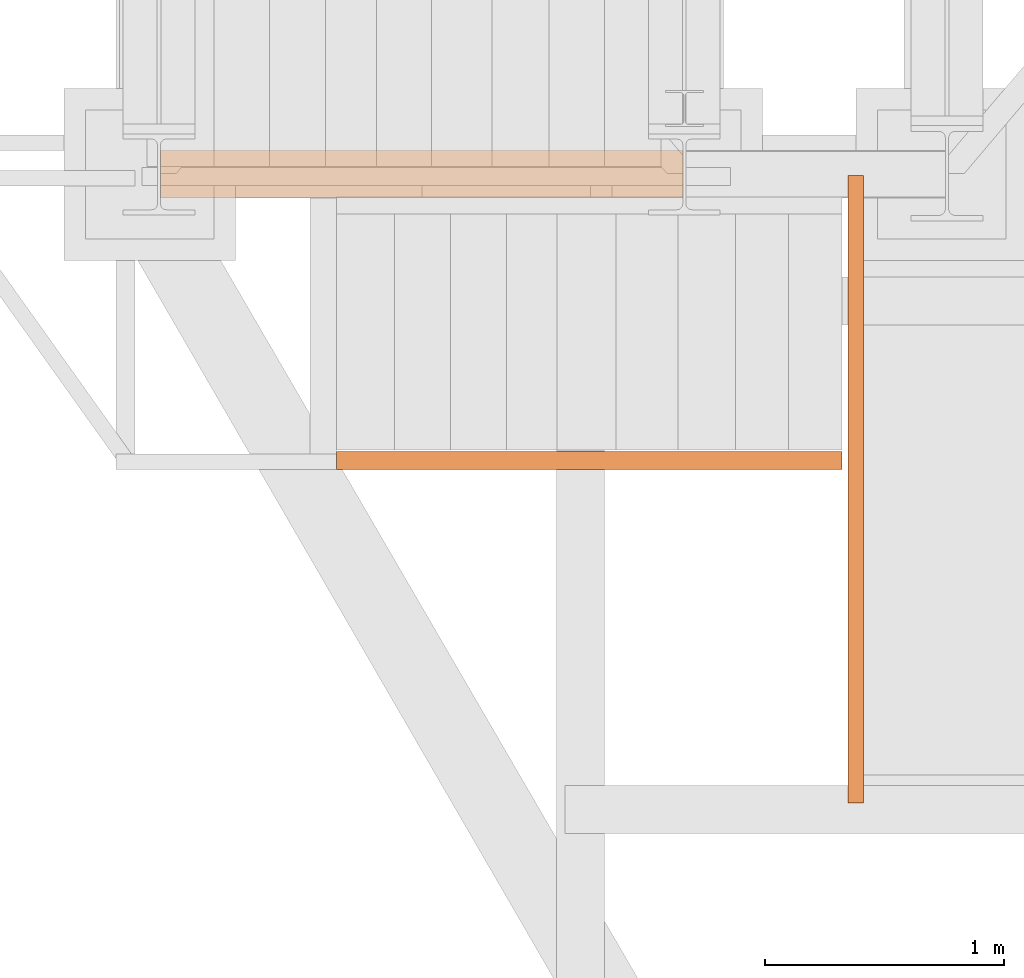
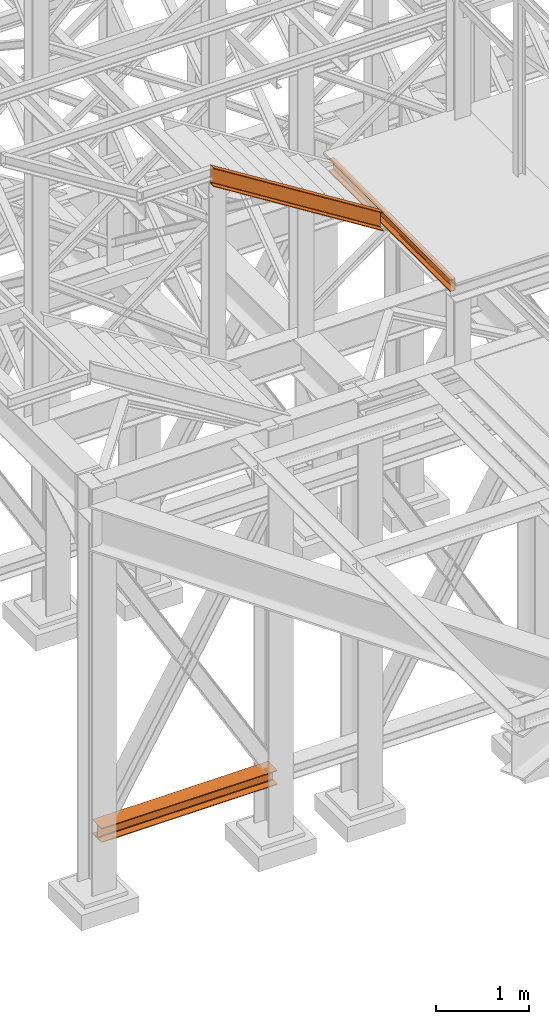
# One storey, part 19 of 208: 3 proxies.
"""IFC2X3 building model written with IfcOpenShell, lengths in millimetres."""

from ifc_helpers import new_model, entity, si_unit, converted_unit, frame, origin, origin_with_axes, place, context, subcontext, project, spatial, faceted_brep, element, save


model = new_model("IFC2X3")

# Units and contexts
model_context = context("Model", 3, precision=1e-05, world=origin())
plan_context = context("Plan", 3, precision=1e-05, world=origin())
body_context = subcontext(model_context, "Body", "Model", "MODEL_VIEW")
ifc_project = project(units=[si_unit("LENGTHUNIT", "METRE", prefix="MILLI"), converted_unit("PLANEANGLEUNIT", "DEGREE", entity("IfcPlaneAngleMeasure", 0.0174532925199433), si_unit("PLANEANGLEUNIT", "RADIAN"), dimensions=[0, 0, 0, 0, 0, 0, 0]), si_unit("AREAUNIT", "SQUARE_METRE"), si_unit("VOLUMEUNIT", "CUBIC_METRE")], contexts=[model_context, plan_context])

# Building, storey
building_placement = place(None, origin())
building = spatial("IfcBuilding", under=ifc_project, at=building_placement, CompositionType="COMPLEX")
storey_placement = place(building_placement, origin_with_axes())
storey = spatial("IfcBuildingStorey", under=building, at=storey_placement, Name="Geschoss", CompositionType="ELEMENT")

# Proxies
proxy_1_placement = place(storey_placement, frame((-3299.995025406559, -17362.5323246858, 544.9900024165573), z_axis=(0.0, 0.0, 1.0), x_axis=(1.0, 0.0, 0.0)))
element("IfcBuildingElementProxy", 1, at=proxy_1_placement, inside=storey, context=body_context, shape_type="Brep", body=[
    faceted_brep([(2188.00999989569, 0.00999999999839929, 190.0100125169756), (2188.00999989569, 200.0100029802306, 190.0100125169756), (2188.00999989569, 200.0100029802306, 180.0100146031382), (2188.00999989569, 121.2600035762771, 180.0100071525576), (2188.00999989569, 111.9441915473326, 178.1454621052744), (2188.00999989569, 105.1245498640819, 171.3258190250399), (2188.00999989569, 103.2600015571697, 162.010007927418), (2188.00999989569, 103.2600015571697, 28.00999713897727), (2188.00999989569, 105.1245498640819, 18.69418604135535), (2188.00999989569, 111.9441915473326, 11.87454296112082), (2188.00999989569, 121.2600035762771, 10.00999791383765), (2188.00999989569, 200.0100029802306, 10.00999791383765), (2188.00999989569, 200.0100029802306, 0.01000000000021828), (2188.00999989569, 0.00999999999839929, 0.01000000000021828), (2188.00999989569, 0.00999999999839929, 10.00999791383765), (2188.00999989569, 78.75999940395195, 10.00999791383765), (2188.00999989569, 88.07581143289644, 11.87454296112082), (2188.00999989569, 94.89545311614711, 18.69418604135535), (2188.00999989569, 96.7600014230593, 28.00999713897727), (2188.00999989569, 96.7600014230593, 162.010007927418), (2188.00999989569, 94.89545311614711, 171.3258190250399), (2188.00999989569, 88.07581143289644, 178.1454621052744), (2188.00999989569, 78.75999940395195, 180.0100071525576), (2188.00999989569, 0.00999999999839929, 180.0100146031382), (2188.00999989569, 200.0100029802306, 190.0100125169756), (2188.00999989569, 0.00999999999839929, 190.0100125169756), (0.01000000000021828, 0.00999999999839929, 190.0100125169755), (0.01000000000021828, 200.0100029802306, 190.0100125169755), (2188.00999989569, 200.0100029802306, 180.0100146031382), (2188.00999989569, 200.0100029802306, 190.0100125169756), (0.01000000000021828, 200.0100029802306, 190.0100125169755), (0.01000000000021828, 200.0100029802306, 180.0100146031381), (2188.00999989569, 121.2600035762771, 180.0100071525576), (2188.00999989569, 200.0100029802306, 180.0100146031382), (0.01000000000021828, 200.0100029802306, 180.0100146031381), (0.01000000000021828, 121.2600035762771, 180.0100071525575), (2188.00999989569, 111.9441915473326, 178.1454621052744), (2188.00999989569, 121.2600035762771, 180.0100071525576), (0.01000000000021828, 121.2600035762771, 180.0100071525575), (0.01000000000021828, 111.9441915473326, 178.1454621052743), (2188.00999989569, 105.1245498640819, 171.3258190250399), (2188.00999989569, 111.9441915473326, 178.1454621052744), (0.01000000000021828, 111.9441915473326, 178.1454621052743), (0.01000000000021828, 105.1245498640819, 171.3258190250398), (2188.00999989569, 103.2600015571697, 162.010007927418), (2188.00999989569, 105.1245498640819, 171.3258190250399), (0.01000000000021828, 105.1245498640819, 171.3258190250398), (0.01000000000021828, 103.2600015571697, 162.0100079274179), (2188.00999989569, 103.2600015571697, 28.00999713897727), (2188.00999989569, 103.2600015571697, 162.010007927418), (0.01000000000021828, 103.2600015571697, 162.0100079274179), (0.01000000000021828, 103.2600015571697, 28.00999713897716), (2188.00999989569, 105.1245498640819, 18.69418604135535), (2188.00999989569, 103.2600015571697, 28.00999713897727), (0.01000000000021828, 103.2600015571697, 28.00999713897716), (0.01000000000021828, 105.1245498640819, 18.69418604135524), (2188.00999989569, 111.9441915473326, 11.87454296112082), (2188.00999989569, 105.1245498640819, 18.69418604135535), (0.01000000000021828, 105.1245498640819, 18.69418604135524), (0.01000000000021828, 111.9441915473326, 11.87454296112071), (2188.00999989569, 121.2600035762771, 10.00999791383765), (2188.00999989569, 111.9441915473326, 11.87454296112082), (0.01000000000021828, 111.9441915473326, 11.87454296112071), (0.01000000000021828, 121.2600035762771, 10.00999791383754), (2188.00999989569, 200.0100029802306, 10.00999791383765), (2188.00999989569, 121.2600035762771, 10.00999791383765), (0.01000000000021828, 121.2600035762771, 10.00999791383754), (0.01000000000021828, 200.0100029802306, 10.00999791383754), (2188.00999989569, 200.0100029802306, 0.01000000000021828), (2188.00999989569, 200.0100029802306, 10.00999791383765), (0.01000000000021828, 200.0100029802306, 10.00999791383754), (0.01000000000021828, 200.0100029802306, 0.01000000000010459), (2188.00999989569, 0.00999999999839929, 0.01000000000021828), (2188.00999989569, 200.0100029802306, 0.01000000000021828), (0.01000000000021828, 200.0100029802306, 0.01000000000010459), (0.01000000000021828, 0.00999999999839929, 0.01000000000010459), (2188.00999989569, 0.00999999999839929, 10.00999791383765), (2188.00999989569, 0.00999999999839929, 0.01000000000021828), (0.01000000000021828, 0.00999999999839929, 0.01000000000010459), (0.01000000000021828, 0.00999999999839929, 10.00999791383754), (2188.00999989569, 78.75999940395195, 10.00999791383765), (2188.00999989569, 0.00999999999839929, 10.00999791383765), (0.01000000000021828, 0.00999999999839929, 10.00999791383754), (0.01000000000021828, 78.75999940395195, 10.00999791383754), (2188.00999989569, 88.07581143289644, 11.87454296112082), (2188.00999989569, 78.75999940395195, 10.00999791383765), (0.01000000000021828, 78.75999940395195, 10.00999791383754), (0.01000000000021828, 88.07581143289644, 11.87454296112071), (2188.00999989569, 94.89545311614711, 18.69418604135535), (2188.00999989569, 88.07581143289644, 11.87454296112082), (0.01000000000021828, 88.07581143289644, 11.87454296112071), (0.01000000000021828, 94.89545311614711, 18.69418604135524), (2188.00999989569, 96.7600014230593, 28.00999713897727), (2188.00999989569, 94.89545311614711, 18.69418604135535), (0.01000000000021828, 94.89545311614711, 18.69418604135524), (0.01000000000021828, 96.7600014230593, 28.00999713897716), (2188.00999989569, 96.7600014230593, 162.010007927418), (2188.00999989569, 96.7600014230593, 28.00999713897727), (0.01000000000021828, 96.7600014230593, 28.00999713897716), (0.01000000000021828, 96.7600014230593, 162.0100079274179), (2188.00999989569, 94.89545311614711, 171.3258190250399), (2188.00999989569, 96.7600014230593, 162.010007927418), (0.01000000000021828, 96.7600014230593, 162.0100079274179), (0.01000000000021828, 94.89545311614711, 171.3258190250398), (2188.00999989569, 88.07581143289644, 178.1454621052744), (2188.00999989569, 94.89545311614711, 171.3258190250399), (0.01000000000021828, 94.89545311614711, 171.3258190250398), (0.01000000000021828, 88.07581143289644, 178.1454621052743), (2188.00999989569, 78.75999940395195, 180.0100071525576), (2188.00999989569, 88.07581143289644, 178.1454621052744), (0.01000000000021828, 88.07581143289644, 178.1454621052743), (0.01000000000021828, 78.75999940395195, 180.0100071525575), (2188.00999989569, 0.00999999999839929, 180.0100146031382), (2188.00999989569, 78.75999940395195, 180.0100071525576), (0.01000000000021828, 78.75999940395195, 180.0100071525575), (0.01000000000021828, 0.00999999999839929, 180.0100146031381), (2188.00999989569, 0.00999999999839929, 190.0100125169756), (2188.00999989569, 0.00999999999839929, 180.0100146031382), (0.01000000000021828, 0.00999999999839929, 180.0100146031381), (0.01000000000021828, 0.00999999999839929, 190.0100125169755), (0.01000000000021828, 0.00999999999839929, 190.0100125169755), (0.01000000000021828, 0.00999999999839929, 180.0100146031381), (0.01000000000021828, 78.75999940395195, 180.0100071525575), (0.01000000000021828, 88.07581143289644, 178.1454621052743), (0.01000000000021828, 94.89545311614711, 171.3258190250398), (0.01000000000021828, 96.7600014230593, 162.0100079274179), (0.01000000000021828, 96.7600014230593, 28.00999713897716), (0.01000000000021828, 94.89545311614711, 18.69418604135524), (0.01000000000021828, 88.07581143289644, 11.87454296112071), (0.01000000000021828, 78.75999940395195, 10.00999791383754), (0.01000000000021828, 0.00999999999839929, 10.00999791383754), (0.01000000000021828, 0.00999999999839929, 0.01000000000010459), (0.01000000000021828, 200.0100029802306, 0.01000000000010459), (0.01000000000021828, 200.0100029802306, 10.00999791383754), (0.01000000000021828, 121.2600035762771, 10.00999791383754), (0.01000000000021828, 111.9441915473326, 11.87454296112071), (0.01000000000021828, 105.1245498640819, 18.69418604135524), (0.01000000000021828, 103.2600015571697, 28.00999713897716), (0.01000000000021828, 103.2600015571697, 162.0100079274179), (0.01000000000021828, 105.1245498640819, 171.3258190250398), (0.01000000000021828, 111.9441915473326, 178.1454621052743), (0.01000000000021828, 121.2600035762771, 180.0100071525575), (0.01000000000021828, 200.0100029802306, 180.0100146031381), (0.01000000000021828, 200.0100029802306, 190.0100125169755)], [[[0, 1, 2, 3, 4, 5, 6, 7, 8, 9, 10, 11, 12, 13, 14, 15, 16, 17, 18, 19, 20, 21, 22, 23]], [[24, 25, 26, 27]], [[28, 29, 30, 31]], [[32, 33, 34, 35]], [[36, 37, 38, 39]], [[40, 41, 42, 43]], [[44, 45, 46, 47]], [[48, 49, 50, 51]], [[52, 53, 54, 55]], [[56, 57, 58, 59]], [[60, 61, 62, 63]], [[64, 65, 66, 67]], [[68, 69, 70, 71]], [[72, 73, 74, 75]], [[76, 77, 78, 79]], [[80, 81, 82, 83]], [[84, 85, 86, 87]], [[88, 89, 90, 91]], [[92, 93, 94, 95]], [[96, 97, 98, 99]], [[100, 101, 102, 103]], [[104, 105, 106, 107]], [[108, 109, 110, 111]], [[112, 113, 114, 115]], [[116, 117, 118, 119]], [[120, 121, 122, 123, 124, 125, 126, 127, 128, 129, 130, 131, 132, 133, 134, 135, 136, 137, 138, 139, 140, 141, 142, 143]]], orient=[[False], [False], [False], [False], [False], [False], [False], [False], [False], [False], [False], [False], [False], [False], [False], [False], [False], [False], [False], [False], [False], [False], [False], [False], [False], [False]]),
])
proxy_2_placement = place(storey_placement, frame((-421.7450362397046, -19894.59359431297, 8324.990002086155), z_axis=(0.0, 0.0, 1.0), x_axis=(1.0, 0.0, 0.0)))
element("IfcBuildingElementProxy", 2, at=proxy_2_placement, inside=storey, context=body_context, shape_type="Brep", body=[
    faceted_brep([(65.00999999999999, 2627.529208944845, 160.0100000000002), (65.00999999999999, 0.00999999999839929, 160.0100000000002), (0.009999999999990905, 0.00999999999839929, 160.0100000000002), (0.009999999999990905, 2627.529208944845, 160.0100000000002), (0.009999999999990905, 2627.529208944845, 160.0100000000002), (0.009999999999990905, 0.00999999999839929, 160.0100000000002), (0.009999999999990905, 0.00999999999839929, 156.8875719297539), (0.009999999999990905, 2627.529208944845, 156.8875719297539), (0.009999999999990905, 2627.529208944845, 156.8875719297539), (0.009999999999990905, 0.00999999999839929, 156.8875719297539), (0.2527365771727546, 0.00999999999839929, 155.2717110918293), (0.2527365771727546, 2627.529208944845, 155.2717110918293), (0.2527365771727546, 2627.529208944845, 155.2717110918293), (0.2527365771727546, 0.00999999999839929, 155.2717110918293), (0.9594677141446937, 0.00999999999839929, 153.7984655565542), (0.9594677141446937, 2627.529208944845, 153.7984655565542), (0.9594677141446937, 2627.529208944845, 153.7984655565542), (0.9594677141446937, 0.00999999999839929, 153.7984655565542), (2.067848361531787, 0.00999999999839929, 152.5978732961266), (2.067848361531787, 2627.529208944845, 152.5978732961266), (2.067848361531787, 2627.529208944845, 152.5978732961266), (2.067848361531787, 0.00999999999839929, 152.5978732961266), (3.480043588516992, 0.00999999999839929, 151.7759086082897), (3.480043588516992, 2627.529208944845, 151.7759086082897), (3.480043588516992, 2627.529208944845, 151.7759086082897), (3.480043588516992, 0.00999999999839929, 151.7759086082897), (5.07140127744583, 0.00999999999839929, 151.4050878978051), (5.07140127744583, 2627.529208944845, 151.4050878978051), (5.07140127744583, 2627.529208944845, 151.4050878978051), (5.07140127744583, 0.00999999999839929, 151.4050878978051), (47.84732483397033, 0.00999999999839929, 147.9830140132835), (47.84732483397033, 2627.529208944845, 147.9830140132835), (47.84732483397033, 2627.529208944845, 147.9830140132835), (47.84732483397033, 0.00999999999839929, 147.9830140132835), (50.81159179199108, 0.00999999999839929, 147.318026761528), (50.81159179199108, 2627.529208944845, 147.318026761528), (50.81159179199108, 2627.529208944845, 147.318026761528), (50.81159179199108, 0.00999999999839929, 147.318026761528), (53.58138040071367, 0.00999999999839929, 145.7058782528511), (53.58138040071367, 2627.529208944845, 145.7058782528511), (53.58138040071367, 2627.529208944845, 145.7058782528511), (53.58138040071367, 0.00999999999839929, 145.7058782528511), (55.69737981845333, 0.00999999999839929, 143.4138384829421), (55.69737981845333, 2627.529208944845, 143.4138384829421), (55.69737981845333, 2627.529208944845, 143.4138384829421), (55.69737981845333, 0.00999999999839929, 143.4138384829421), (57.04659380721364, 0.00999999999839929, 140.6012788246917), (57.04659380721364, 2627.529208944845, 140.6012788246917), (57.04659380721364, 2627.529208944845, 140.6012788246917), (57.04659380721364, 0.00999999999839929, 140.6012788246917), (57.50999999999999, 0.00999999999839929, 137.5164535886543), (57.50999999999999, 2627.529208944845, 137.5164535886543), (57.50999999999999, 2627.529208944845, 137.5164535886543), (57.50999999999999, 0.00999999999839929, 137.5164535886543), (57.50999999999999, 0.00999999999839929, 22.503546411348), (57.50999999999999, 2627.529208944845, 22.503546411348), (57.50999999999999, 2627.529208944845, 22.503546411348), (57.50999999999999, 0.00999999999839929, 22.503546411348), (57.04659380721364, 0.00999999999839929, 19.41872117530875), (57.04659380721364, 2627.529208944845, 19.41872117530875), (57.04659380721364, 2627.529208944845, 19.41872117530875), (57.04659380721364, 0.00999999999839929, 19.41872117530875), (55.69737981845333, 0.00999999999839929, 16.60616151705835), (55.69737981845333, 2627.529208944845, 16.60616151705835), (55.69737981845333, 2627.529208944845, 16.60616151705835), (55.69737981845333, 0.00999999999839929, 16.60616151705835), (53.58138040071367, 0.00999999999839929, 14.31412174714933), (53.58138040071367, 2627.529208944845, 14.31412174714933), (53.58138040071367, 2627.529208944845, 14.31412174714933), (53.58138040071367, 0.00999999999839929, 14.31412174714933), (50.88537133101795, 0.00999999999839929, 12.74491643400688), (50.88537133101795, 2627.529208944845, 12.74491643400688), (50.88537133101795, 2627.529208944845, 12.74491643400688), (50.88537133101795, 0.00999999999839929, 12.74491643400688), (47.84732483397033, 0.00999999999839929, 12.03698598671872), (47.84732483397033, 2627.529208944845, 12.03698598671872), (47.84732483397033, 2627.529208944845, 12.03698598671872), (47.84732483397033, 0.00999999999839929, 12.03698598671872), (5.07140127744583, 0.00999999999839929, 8.614912102195376), (5.07140127744583, 2627.529208944845, 8.614912102195376), (5.07140127744583, 2627.529208944845, 8.614912102195376), (5.07140127744583, 0.00999999999839929, 8.614912102195376), (3.480043588516992, 0.00999999999839929, 8.244091391710754), (3.480043588516992, 2627.529208944845, 8.244091391710754), (3.480043588516992, 2627.529208944845, 8.244091391710754), (3.480043588516992, 0.00999999999839929, 8.244091391710754), (2.067848361531787, 0.00999999999839929, 7.422126703873801), (2.067848361531787, 2627.529208944845, 7.422126703873801), (2.067848361531787, 2627.529208944845, 7.422126703873801), (2.067848361531787, 0.00999999999839929, 7.422126703873801), (0.9594677141446937, 0.00999999999839929, 6.221534443446217), (0.9594677141446937, 2627.529208944845, 6.221534443446217), (0.9594677141446937, 2627.529208944845, 6.221534443446217), (0.9594677141446937, 0.00999999999839929, 6.221534443446217), (0.2527365771727546, 0.00999999999839929, 4.748288908172981), (0.2527365771727546, 2627.529208944845, 4.748288908172981), (0.2527365771727546, 2627.529208944845, 4.748288908172981), (0.2527365771727546, 0.00999999999839929, 4.748288908172981), (0.009999999999990905, 0.00999999999839929, 0.01000000000021828), (0.009999999999990905, 2627.529208944845, 0.01000000000021828), (0.009999999999990905, 2627.529208944845, 0.01000000000021828), (0.009999999999990905, 0.00999999999839929, 0.01000000000021828), (65.00999999999999, 0.00999999999839929, 0.01000000000021828), (65.00999999999999, 2627.529208944845, 0.01000000000021828), (65.00999999999999, 2627.529208944845, 0.01000000000021828), (65.00999999999999, 0.00999999999839929, 0.01000000000021828), (65.00999999999999, 0.00999999999839929, 160.0100000000002), (65.00999999999999, 2627.529208944845, 160.0100000000002), (65.00999999999999, 2627.529208944845, 160.0100000000002), (0.009999999999990905, 2627.529208944845, 160.0100000000002), (0.009999999999990905, 2627.529208944845, 156.8875719297539), (0.2527365771727546, 2627.529208944845, 155.2717110918293), (0.9594677141446937, 2627.529208944845, 153.7984655565542), (2.067848361531787, 2627.529208944845, 152.5978732961266), (3.480043588516992, 2627.529208944845, 151.7759086082897), (5.07140127744583, 2627.529208944845, 151.4050878978051), (47.84732483397033, 2627.529208944845, 147.9830140132835), (50.81159179199108, 2627.529208944845, 147.318026761528), (53.58138040071367, 2627.529208944845, 145.7058782528511), (55.69737981845333, 2627.529208944845, 143.4138384829421), (57.04659380721364, 2627.529208944845, 140.6012788246917), (57.50999999999999, 2627.529208944845, 137.5164535886543), (57.50999999999999, 2627.529208944845, 22.503546411348), (57.04659380721364, 2627.529208944845, 19.41872117530875), (55.69737981845333, 2627.529208944845, 16.60616151705835), (53.58138040071367, 2627.529208944845, 14.31412174714933), (50.88537133101795, 2627.529208944845, 12.74491643400688), (47.84732483397033, 2627.529208944845, 12.03698598671872), (5.07140127744583, 2627.529208944845, 8.614912102195376), (3.480043588516992, 2627.529208944845, 8.244091391710754), (2.067848361531787, 2627.529208944845, 7.422126703873801), (0.9594677141446937, 2627.529208944845, 6.221534443446217), (0.2527365771727546, 2627.529208944845, 4.748288908172981), (0.009999999999990905, 2627.529208944845, 0.01000000000021828), (65.00999999999999, 2627.529208944845, 0.01000000000021828), (65.00999999999999, 0.00999999999839929, 160.0100000000002), (65.00999999999999, 0.00999999999839929, 0.01000000000021828), (0.009999999999990905, 0.00999999999839929, 0.01000000000021828), (0.2527365771727546, 0.00999999999839929, 4.748288908172981), (0.9594677141446937, 0.00999999999839929, 6.221534443446217), (2.067848361531787, 0.00999999999839929, 7.422126703873801), (3.480043588516992, 0.00999999999839929, 8.244091391710754), (5.07140127744583, 0.00999999999839929, 8.614912102195376), (47.84732483397033, 0.00999999999839929, 12.03698598671872), (50.88537133101795, 0.00999999999839929, 12.74491643400688), (53.58138040071367, 0.00999999999839929, 14.31412174714933), (55.69737981845333, 0.00999999999839929, 16.60616151705835), (57.04659380721364, 0.00999999999839929, 19.41872117530875), (57.50999999999999, 0.00999999999839929, 22.503546411348), (57.50999999999999, 0.00999999999839929, 137.5164535886543), (57.04659380721364, 0.00999999999839929, 140.6012788246917), (55.69737981845333, 0.00999999999839929, 143.4138384829421), (53.58138040071367, 0.00999999999839929, 145.7058782528511), (50.81159179199108, 0.00999999999839929, 147.318026761528), (47.84732483397033, 0.00999999999839929, 147.9830140132835), (5.07140127744583, 0.00999999999839929, 151.4050878978051), (3.480043588516992, 0.00999999999839929, 151.7759086082897), (2.067848361531787, 0.00999999999839929, 152.5978732961266), (0.9594677141446937, 0.00999999999839929, 153.7984655565542), (0.2527365771727546, 0.00999999999839929, 155.2717110918293), (0.009999999999990905, 0.00999999999839929, 156.8875719297539), (0.009999999999990905, 0.00999999999839929, 160.0100000000002)], [[[0, 1, 2, 3]], [[4, 5, 6, 7]], [[8, 9, 10, 11]], [[12, 13, 14, 15]], [[16, 17, 18, 19]], [[20, 21, 22, 23]], [[24, 25, 26, 27]], [[28, 29, 30, 31]], [[32, 33, 34, 35]], [[36, 37, 38, 39]], [[40, 41, 42, 43]], [[44, 45, 46, 47]], [[48, 49, 50, 51]], [[52, 53, 54, 55]], [[56, 57, 58, 59]], [[60, 61, 62, 63]], [[64, 65, 66, 67]], [[68, 69, 70, 71]], [[72, 73, 74, 75]], [[76, 77, 78, 79]], [[80, 81, 82, 83]], [[84, 85, 86, 87]], [[88, 89, 90, 91]], [[92, 93, 94, 95]], [[96, 97, 98, 99]], [[100, 101, 102, 103]], [[104, 105, 106, 107]], [[108, 109, 110, 111, 112, 113, 114, 115, 116, 117, 118, 119, 120, 121, 122, 123, 124, 125, 126, 127, 128, 129, 130, 131, 132, 133, 134]], [[135, 136, 137, 138, 139, 140, 141, 142, 143, 144, 145, 146, 147, 148, 149, 150, 151, 152, 153, 154, 155, 156, 157, 158, 159, 160, 161]]], orient=[[False], [False], [False], [False], [False], [False], [False], [False], [False], [False], [False], [False], [False], [False], [False], [False], [False], [False], [False], [False], [False], [False], [False], [False], [False], [False], [False], [False], [False]]),
])
proxy_3_placement = place(storey_placement, frame((-2563.970189809399, -18497.574391808, 8284.990002086157), z_axis=(0.0, 0.0, 1.0), x_axis=(1.0, 0.0, 0.0)))
element("IfcBuildingElementProxy", 3, at=proxy_3_placement, inside=storey, context=body_context, shape_type="Brep", body=[
    faceted_brep([(0.01000000000021828, 75.01000111758549, 1575.009997913843), (0.01000000000021828, 75.01000111758549, 1329.446611849271), (2117.845950178831, 75.01000111758549, 0.01000000000021828), (2117.845950178831, 75.01000111758549, 245.5733860645723), (0.01000000000021828, 0.00999999999839929, 1575.009997913843), (0.01000000000021828, 75.01000111758549, 1575.009997913843), (2117.845950178831, 75.01000111758549, 245.5733860645723), (2117.845950178831, 0.00999999999839929, 245.5733860645723), (0.01000000000021828, 0.00999999999839929, 1571.374639628151), (0.01000000000021828, 0.00999999999839929, 1575.009997913843), (2117.845950178831, 0.00999999999839929, 245.5733860645723), (2117.845950178831, 0.00999999999839929, 241.9380277788805), (0.01000000000021828, 1.126000115869829, 1565.974696894798), (0.01000000000021828, 0.00999999999839929, 1571.374639628151), (2117.845950178831, 0.00999999999839929, 241.9380277788805), (2117.845950178831, 1.126000115869829, 236.5380850455276), (0.01000000000021828, 5.531528422830888, 1564.031196863312), (0.01000000000021828, 1.126000115869829, 1565.974696894798), (2117.845950178831, 1.126000115869829, 236.5380850455276), (2117.845950178831, 5.531528422830888, 234.5945850140433), (0.01000000000021828, 55.92706931590874, 1559.081077071371), (0.01000000000021828, 5.531528422830888, 1564.031196863312), (2117.845950178831, 5.531528422830888, 234.5945850140433), (2117.845950178831, 55.92706931590874, 229.6444652221016), (0.01000000000021828, 61.66620032697756, 1557.12243718452), (0.01000000000021828, 55.92706931590874, 1559.081077071371), (2117.845950178831, 55.92706931590874, 229.6444652221016), (2117.845950178831, 61.66620032697756, 227.6858253352511), (0.01000000000021828, 65.51985109060843, 1551.867013747282), (0.01000000000021828, 61.66620032697756, 1557.12243718452), (2117.845950178831, 61.66620032697756, 227.6858253352511), (2117.845950178831, 65.51985109060843, 222.430401898011), (0.01000000000021828, 66.51000065564949, 1545.006152728727), (0.01000000000021828, 65.51985109060843, 1551.867013747282), (2117.845950178831, 65.51985109060843, 222.430401898011), (2117.845950178831, 66.51000065564949, 215.5695408794563), (0.01000000000021828, 66.51000065564949, 1359.450457034389), (0.01000000000021828, 66.51000065564949, 1545.006152728727), (2117.845950178831, 66.51000065564949, 215.5695408794563), (2117.845950178831, 66.51000065564949, 30.01384518511804), (0.01000000000021828, 65.51985109060843, 1352.589596015832), (0.01000000000021828, 66.51000065564949, 1359.450457034389), (2117.845950178831, 66.51000065564949, 30.01384518511804), (2117.845950178831, 65.51985109060843, 23.15298416656151), (0.01000000000021828, 61.66620032697756, 1347.334172578592), (0.01000000000021828, 65.51985109060843, 1352.589596015832), (2117.845950178831, 65.51985109060843, 23.15298416656151), (2117.845950178831, 61.66620032697756, 17.89756072932141), (0.01000000000021828, 55.92706931590874, 1345.375532691742), (0.01000000000021828, 61.66620032697756, 1347.334172578592), (2117.845950178831, 61.66620032697756, 17.89756072932141), (2117.845950178831, 55.92706931590874, 15.93892084247273), (0.01000000000021828, 5.531528422830888, 1340.425412899804), (0.01000000000021828, 55.92706931590874, 1345.375532691742), (2117.845950178831, 55.92706931590874, 15.93892084247273), (2117.845950178831, 5.531528422830888, 10.98880105053104), (0.01000000000021828, 1.126000115869829, 1338.481912868316), (0.01000000000021828, 5.531528422830888, 1340.425412899804), (2117.845950178831, 5.531528422830888, 10.98880105053104), (2117.845950178831, 1.126000115869829, 9.045301019044928), (0.01000000000021828, 0.00999999999839929, 1333.081970134965), (0.01000000000021828, 1.126000115869829, 1338.481912868316), (2117.845950178831, 1.126000115869829, 9.045301019044928), (2117.845950178831, 0.00999999999839929, 3.645358285693874), (0.01000000000021828, 0.00999999999839929, 1329.446611849271), (0.01000000000021828, 0.00999999999839929, 1333.081970134965), (2117.845950178831, 0.00999999999839929, 3.645358285693874), (2117.845950178831, 0.00999999999839929, 0.01000000000021828), (0.01000000000021828, 75.01000111758549, 1329.446611849271), (0.01000000000021828, 0.00999999999839929, 1329.446611849271), (2117.845950178831, 0.00999999999839929, 0.01000000000021828), (2117.845950178831, 75.01000111758549, 0.01000000000021828), (2117.845950178831, 75.01000111758549, 0.01000000000021828), (2117.845950178831, 0.00999999999839929, 0.01000000000021828), (2117.845950178831, 0.00999999999839929, 3.645358285693874), (2117.845950178831, 1.126000115869829, 9.045301019044928), (2117.845950178831, 5.531528422830888, 10.98880105053104), (2117.845950178831, 55.92706931590874, 15.93892084247273), (2117.845950178831, 61.66620032697756, 17.89756072932141), (2117.845950178831, 65.51985109060843, 23.15298416656151), (2117.845950178831, 66.51000065564949, 30.01384518511804), (2117.845950178831, 66.51000065564949, 215.5695408794563), (2117.845950178831, 65.51985109060843, 222.430401898011), (2117.845950178831, 61.66620032697756, 227.6858253352511), (2117.845950178831, 55.92706931590874, 229.6444652221016), (2117.845950178831, 5.531528422830888, 234.5945850140433), (2117.845950178831, 1.126000115869829, 236.5380850455276), (2117.845950178831, 0.00999999999839929, 241.9380277788805), (2117.845950178831, 0.00999999999839929, 245.5733860645723), (2117.845950178831, 75.01000111758549, 245.5733860645723), (0.01000000000021828, 75.01000111758549, 1575.009997913843), (0.01000000000021828, 0.00999999999839929, 1575.009997913843), (0.01000000000021828, 0.00999999999839929, 1571.374639628151), (0.01000000000021828, 1.126000115869829, 1565.974696894798), (0.01000000000021828, 5.531528422830888, 1564.031196863312), (0.01000000000021828, 55.92706931590874, 1559.081077071371), (0.01000000000021828, 61.66620032697756, 1557.12243718452), (0.01000000000021828, 65.51985109060843, 1551.867013747282), (0.01000000000021828, 66.51000065564949, 1545.006152728727), (0.01000000000021828, 66.51000065564949, 1359.450457034389), (0.01000000000021828, 65.51985109060843, 1352.589596015832), (0.01000000000021828, 61.66620032697756, 1347.334172578592), (0.01000000000021828, 55.92706931590874, 1345.375532691742), (0.01000000000021828, 5.531528422830888, 1340.425412899804), (0.01000000000021828, 1.126000115869829, 1338.481912868316), (0.01000000000021828, 0.00999999999839929, 1333.081970134965), (0.01000000000021828, 0.00999999999839929, 1329.446611849271), (0.01000000000021828, 75.01000111758549, 1329.446611849271)], [[[0, 1, 2, 3]], [[4, 5, 6, 7]], [[8, 9, 10, 11]], [[12, 13, 14, 15]], [[16, 17, 18, 19]], [[20, 21, 22, 23]], [[24, 25, 26, 27]], [[28, 29, 30, 31]], [[32, 33, 34, 35]], [[36, 37, 38, 39]], [[40, 41, 42, 43]], [[44, 45, 46, 47]], [[48, 49, 50, 51]], [[52, 53, 54, 55]], [[56, 57, 58, 59]], [[60, 61, 62, 63]], [[64, 65, 66, 67]], [[68, 69, 70, 71]], [[72, 73, 74, 75, 76, 77, 78, 79, 80, 81, 82, 83, 84, 85, 86, 87, 88, 89]], [[90, 91, 92, 93, 94, 95, 96, 97, 98, 99, 100, 101, 102, 103, 104, 105, 106, 107]]], orient=[[False], [False], [False], [False], [False], [False], [False], [False], [False], [False], [False], [False], [False], [False], [False], [False], [False], [False], [False], [False]]),
])

save(model, "model.ifc")
